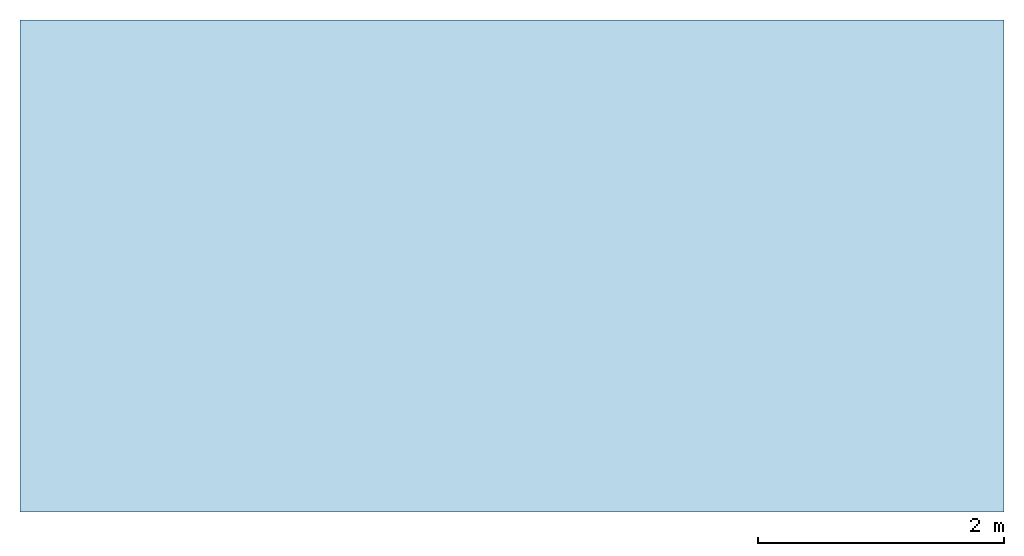
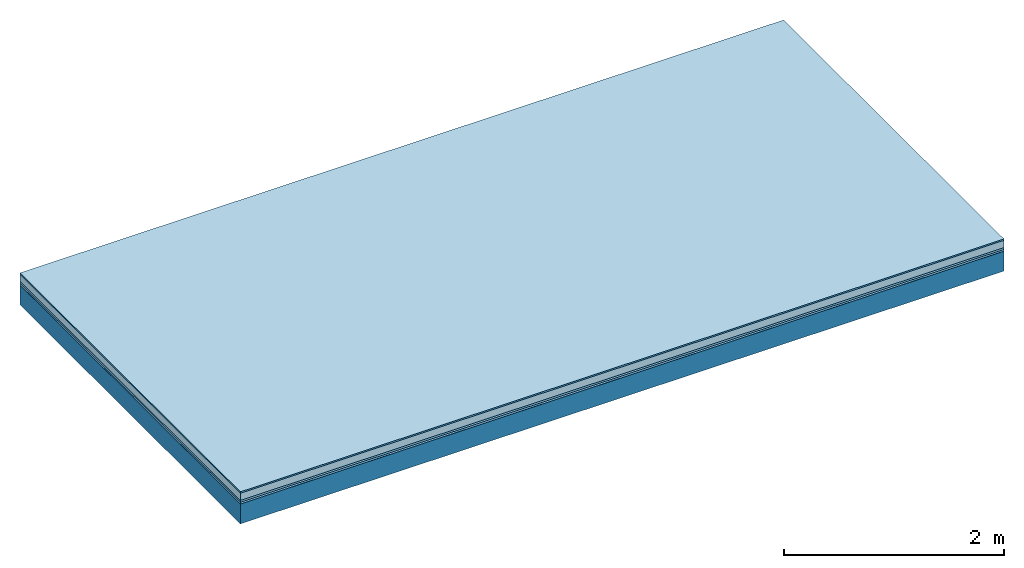
# One storey: 5 plates, 1 member, 1 element without a shape of its own.
"""IFC4 building model written with IfcOpenShell, lengths in metres."""

from ifc_helpers import new_model, si_unit, derived_unit, direction, frame, frame_2d, origin, origin_with_axes, place, context, project, spatial, rectangle, extrude, material, layer, layer_set, type_object, element, aggregate, save


model = new_model("IFC4")

# Units and contexts
plan_context = context("Plan", 3, precision=1e-05, world=origin(), true_north=direction((0.0, 1.0)))
model_context = context("Model", 3, precision=1e-05, world=origin(), true_north=direction((0.0, 1.0)))
ifc_project = project(units=[si_unit("LENGTHUNIT", "METRE"), derived_unit("SOUNDPRESSUREUNIT", [(si_unit("PRESSUREUNIT", "PASCAL", prefix="MICRO"), 0)]), si_unit("ENERGYUNIT", "JOULE", prefix="MEGA"), si_unit("MASSUNIT", "GRAM", prefix="KILO"), derived_unit("THERMALTRANSMITTANCEUNIT", [(si_unit("POWERUNIT", "WATT"), 1), (si_unit("AREAUNIT", "SQUARE_METRE"), -1), (si_unit("THERMODYNAMICTEMPERATUREUNIT", "KELVIN"), -1)]), derived_unit("AREADENSITYUNIT", [(si_unit("MASSUNIT", "GRAM", prefix="KILO"), 1), (si_unit("AREAUNIT", "SQUARE_METRE"), -1)]), derived_unit("USERDEFINED", [(si_unit("ENERGYUNIT", "JOULE", prefix="MEGA"), 1), (si_unit("AREAUNIT", "SQUARE_METRE"), -1)])], contexts=[plan_context, model_context])

# Site, building, storey
site = spatial("IfcSite", under=ifc_project)
building_placement = place(None, origin())
building = spatial("IfcBuilding", under=site, at=building_placement)
storey_placement = place(building_placement, origin())
storey = spatial("IfcBuildingStorey", under=building, at=storey_placement)

# Slab, member, plates
ifc_material_1 = material(Category="11.013")
ifc_layer_1 = layer(ifc_material_1, 0.015, Name="Flooring")
ifc_material_2 = material(Name="Cement screed", Category="04.006")
ifc_layer_2 = layer(ifc_material_2, 0.08, Name="On-material")
ifc_material_3 = material(Name="Wood fiber generic product", Category="10.009")
ifc_layer_3 = layer(ifc_material_3, 0.02, Name="Impact sound insulation")
ifc_material_4 = material()
ifc_layer_4 = layer(ifc_material_4, 0.02, Name="Additional insulation")
ifc_material_5 = material(Name="protection", Category="09.007")
ifc_layer_5 = layer(ifc_material_5, 0.0005, Name="Sub-floor")
ifc_material_6 = material(Name="no composite action")
ifc_layer_6 = layer(ifc_material_6, 0.0, Name="Bond")
ifc_layer_7 = layer(None, 0.22, Name="Supporting structure")
ifc_layer_set = layer_set([ifc_layer_1, ifc_layer_2, ifc_layer_3, ifc_layer_4, ifc_layer_5, ifc_layer_6, ifc_layer_7])
slab_type = type_object("IfcSlabType", Name="A2074", PredefinedType="NOTDEFINED", material=ifc_layer_set)
slab_placement = place(None, frame((0.0, 0.0, 0.0), z_axis=(0.0, 0.0, -1.0), x_axis=(1.0, 0.0, 0.0)))
slab = element("IfcSlab", 1, at=slab_placement, inside=storey, type_object=slab_type, material=ifc_layer_set, Name="Slab #1")
ifc_material_7 = material(Name="Solid timber panel")
member_placement = place(slab_placement, origin())
member = element("IfcMember", 2, at=member_placement, material=ifc_material_7, Name="Supporting structure", context=plan_context, shape_type="SweptSolid", body=[
    extrude(rectangle(XDim=1.0, YDim=0.22, at=frame_2d((0.5, 0.11), x_axis=(1.0, 0.0))), frame((0.0, 4.0, 0.1355), z_axis=(0.0, -1.0, 0.0), x_axis=(1.0, 0.0, 0.0)), (0.0, 0.0, 1.0), 4.0),
    extrude(rectangle(XDim=1.0, YDim=0.22, at=frame_2d((0.5, 0.11), x_axis=(1.0, 0.0))), frame((1.0, 4.0, 0.1355), z_axis=(0.0, -1.0, 0.0), x_axis=(1.0, 0.0, 0.0)), (0.0, 0.0, 1.0), 4.0),
    extrude(rectangle(XDim=1.0, YDim=0.22, at=frame_2d((0.5, 0.11), x_axis=(1.0, 0.0))), frame((2.0, 4.0, 0.1355), z_axis=(0.0, -1.0, 0.0), x_axis=(1.0, 0.0, 0.0)), (0.0, 0.0, 1.0), 4.0),
    extrude(rectangle(XDim=1.0, YDim=0.22, at=frame_2d((0.5, 0.11), x_axis=(1.0, 0.0))), frame((3.0, 4.0, 0.1355), z_axis=(0.0, -1.0, 0.0), x_axis=(1.0, 0.0, 0.0)), (0.0, 0.0, 1.0), 4.0),
    extrude(rectangle(XDim=1.0, YDim=0.22, at=frame_2d((0.5, 0.11), x_axis=(1.0, 0.0))), frame((4.0, 4.0, 0.1355), z_axis=(0.0, -1.0, 0.0), x_axis=(1.0, 0.0, 0.0)), (0.0, 0.0, 1.0), 4.0),
    extrude(rectangle(XDim=1.0, YDim=0.22, at=frame_2d((0.5, 0.11), x_axis=(1.0, 0.0))), frame((5.0, 4.0, 0.1355), z_axis=(0.0, -1.0, 0.0), x_axis=(1.0, 0.0, 0.0)), (0.0, 0.0, 1.0), 4.0),
    extrude(rectangle(XDim=1.0, YDim=0.22, at=frame_2d((0.5, 0.11), x_axis=(1.0, 0.0))), frame((6.0, 4.0, 0.1355), z_axis=(0.0, -1.0, 0.0), x_axis=(1.0, 0.0, 0.0)), (0.0, 0.0, 1.0), 4.0),
    extrude(rectangle(XDim=1.0, YDim=0.22, at=frame_2d((0.5, 0.11), x_axis=(1.0, 0.0))), frame((7.0, 4.0, 0.1355), z_axis=(0.0, -1.0, 0.0), x_axis=(1.0, 0.0, 0.0)), (0.0, 0.0, 1.0), 4.0),
])
plate_1_placement = place(slab_placement, origin())
plate_1 = element("IfcPlate", 3, at=plate_1_placement, material=ifc_material_1, Name="Flooring", context=plan_context, shape_type="SweptSolid", body=[
    extrude(rectangle(XDim=8.0, YDim=4.0, at=frame_2d((4.0, 2.0), x_axis=(1.0, 0.0))), origin_with_axes(), (0.0, 0.0, 1.0), 0.015),
])
plate_2_placement = place(slab_placement, origin())
plate_2 = element("IfcPlate", 4, at=plate_2_placement, material=ifc_material_2, Name="On-material", context=plan_context, shape_type="SweptSolid", body=[
    extrude(rectangle(XDim=8.0, YDim=4.0, at=frame_2d((4.0, 2.0), x_axis=(1.0, 0.0))), frame((0.0, 0.0, 0.015), z_axis=(0.0, 0.0, 1.0), x_axis=(1.0, 0.0, 0.0)), (0.0, 0.0, 1.0), 0.08),
])
plate_3_placement = place(slab_placement, origin())
plate_3 = element("IfcPlate", 5, at=plate_3_placement, material=ifc_material_3, Name="Impact sound insulation", context=plan_context, shape_type="SweptSolid", body=[
    extrude(rectangle(XDim=8.0, YDim=4.0, at=frame_2d((4.0, 2.0), x_axis=(1.0, 0.0))), frame((0.0, 0.0, 0.095), z_axis=(0.0, 0.0, 1.0), x_axis=(1.0, 0.0, 0.0)), (0.0, 0.0, 1.0), 0.02),
])
plate_4_placement = place(slab_placement, origin())
plate_4 = element("IfcPlate", 6, at=plate_4_placement, material=ifc_material_4, Name="Additional insulation", context=plan_context, shape_type="SweptSolid", body=[
    extrude(rectangle(XDim=8.0, YDim=4.0, at=frame_2d((4.0, 2.0), x_axis=(1.0, 0.0))), frame((0.0, 0.0, 0.115), z_axis=(0.0, 0.0, 1.0), x_axis=(1.0, 0.0, 0.0)), (0.0, 0.0, 1.0), 0.02),
])
plate_5_placement = place(slab_placement, origin())
plate_5 = element("IfcPlate", 7, at=plate_5_placement, material=ifc_material_5, Name="Sub-floor", context=plan_context, shape_type="SweptSolid", body=[
    extrude(rectangle(XDim=8.0, YDim=4.0, at=frame_2d((4.0, 2.0), x_axis=(1.0, 0.0))), frame((0.0, 0.0, 0.135), z_axis=(0.0, 0.0, 1.0), x_axis=(1.0, 0.0, 0.0)), (0.0, 0.0, 1.0), 0.0005),
])
aggregate(slab, [plate_1, plate_2, plate_3, plate_4, plate_5, member])

save(model, "model.ifc")
